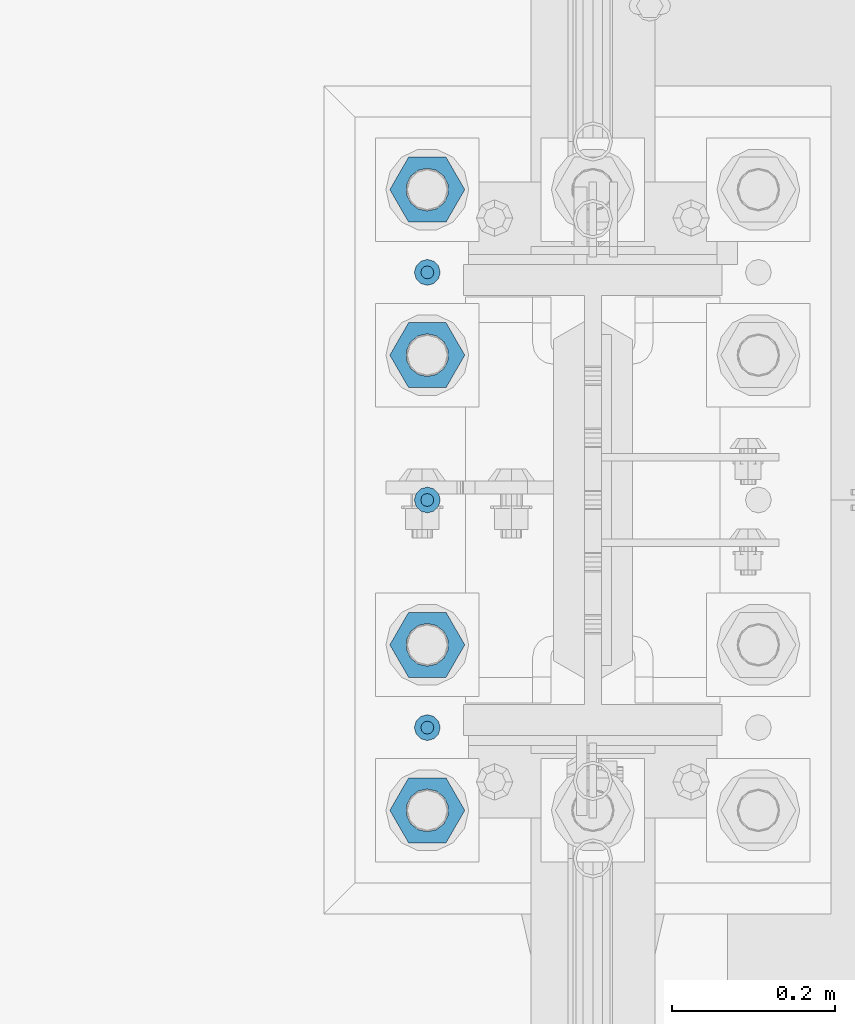
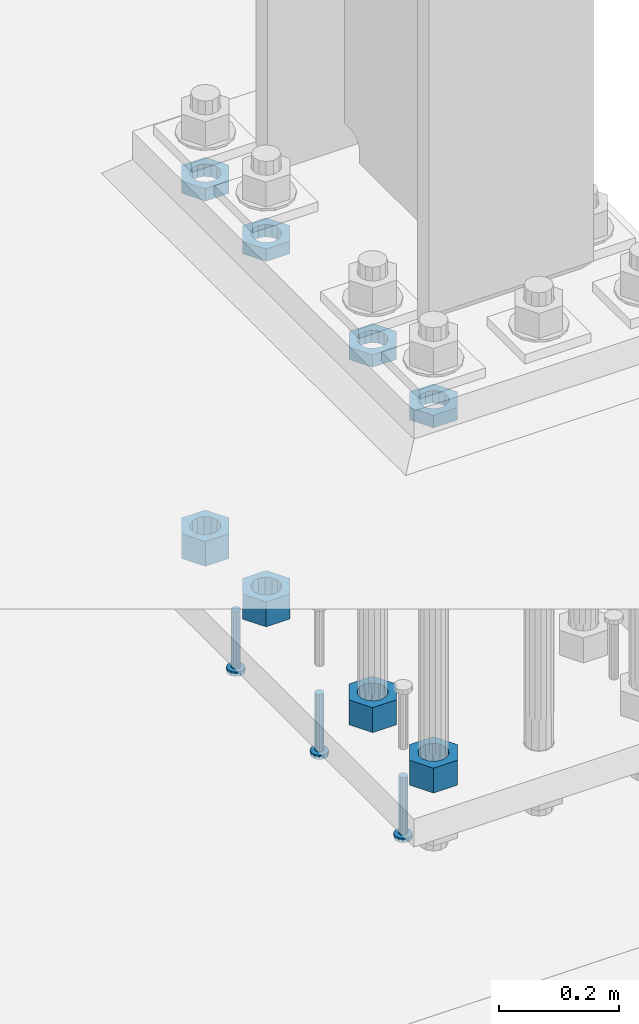
# One storey, part 1301 of 1876: 11 beams, 1 element without a shape of its own.
"""IFC2X3 building model written with IfcOpenShell, lengths in millimetres."""

from ifc_helpers import new_model, si_unit, frame, origin_with_axes, place, context, subcontext, project, spatial, faceted_brep, material, type_object, element, aggregate, save


model = new_model("IFC2X3")

# Units and contexts
model_context = context("Model", 3, precision=1e-05, world=origin_with_axes())
body_context = subcontext(model_context, "Body", "Model", "MODEL_VIEW")
ifc_project = project(units=[si_unit("LENGTHUNIT", "METRE", prefix="MILLI"), si_unit("AREAUNIT", "SQUARE_METRE"), si_unit("VOLUMEUNIT", "CUBIC_METRE"), si_unit("MASSUNIT", "GRAM", prefix="KILO"), si_unit("TIMEUNIT", "SECOND"), si_unit("PLANEANGLEUNIT", "RADIAN"), si_unit("SOLIDANGLEUNIT", "STERADIAN"), si_unit("THERMODYNAMICTEMPERATUREUNIT", "DEGREE_CELSIUS"), si_unit("LUMINOUSINTENSITYUNIT", "LUMEN")], contexts=[model_context])

# Site, building, storey
site_placement = place(None, origin_with_axes())
site = spatial("IfcSite", under=ifc_project, at=site_placement, CompositionType="ELEMENT")
building_placement = place(site_placement, origin_with_axes())
building = spatial("IfcBuilding", under=site, at=building_placement, Name="Undefined", CompositionType="ELEMENT")
storey_placement = place(building_placement, origin_with_axes())
storey = spatial("IfcBuildingStorey", under=building, at=storey_placement, Name="Undefined", CompositionType="ELEMENT", Elevation=0.0)

# Assembly, beams
assembly_placement = place(storey_placement, origin_with_axes())
assembly = element("IfcElementAssembly", 1, at=assembly_placement, inside=storey, Name="TEMPLATE", AssemblyPlace="NOTDEFINED", PredefinedType="RIGID_FRAME")
ifc_material_1 = material(Name="STEEL/A563")
beam_type_1 = type_object("IfcBeamType", Name="2_DIA. HALF_NUT", PredefinedType="NOTDEFINED")
beam_1_placement = place(assembly_placement, frame((7416.8, 8000.99999847412, 33.3375), z_axis=(0.0, -1.0, 0.0), x_axis=(0.0, 0.0, -1.0)))
beam_1 = element("IfcBeam", 2, at=beam_1_placement, type_object=beam_type_1, material=ifc_material_1, Name="NUT", ObjectType="2_DIA. HALF_NUT", context=body_context, shape_type="Brep", body=[
    faceted_brep([(0.0, -46.0369987487793, 9.09494701772928e-13), (0.0, -23.0184993743896, -39.869213104248), (25.4, -23.0184993743896, -39.869213104248), (25.4, -46.0369987487793, 9.09494701772928e-13), (0.0, 23.0184993743896, -39.869213104248), (25.4, 23.0184993743896, -39.869213104248), (0.0, 46.0369987487793, -9.09494701772928e-13), (25.4, 46.0369987487793, -9.09494701772928e-13), (0.0, 23.0184993743896, 39.869213104248), (25.4, 23.0184993743896, 39.869213104248), (0.0, -23.0184993743896, 39.869213104248), (25.4, -23.0184993743896, 39.869213104248), (0.0, 0.0, 26.1940002441406), (0.0, 11.3650617044514, 23.5999013092769), (25.4, 11.3650617044514, 23.5999013092769), (25.4, 0.0, 26.1940002441406), (0.0, 20.4791109456437, 16.3316083006703), (25.4, 20.4791109456437, 16.3316083006703), (0.0, 25.5370200498346, 5.82867859874477), (25.4, 25.5370200498346, 5.82867859874477), (0.0, 25.5370200498346, -5.82867859874477), (25.4, 25.5370200498346, -5.82867859874477), (0.0, 20.4791109456437, -16.3316083006703), (25.4, 20.4791109456437, -16.3316083006703), (0.0, 11.3650617044514, -23.5999013092769), (25.4, 11.3650617044514, -23.5999013092769), (0.0, 0.0, -26.1940002441406), (25.4, 0.0, -26.1940002441406), (0.0, -11.3650617044514, -23.5999013092769), (25.4, -11.3650617044514, -23.5999013092769), (0.0, -20.4791109456437, -16.3316083006703), (25.4, -20.4791109456437, -16.3316083006703), (0.0, -25.5370200498346, -5.82867859874477), (25.4, -25.5370200498346, -5.82867859874477), (0.0, -25.5370200498346, 5.82867859874477), (25.4, -25.5370200498346, 5.82867859874477), (0.0, -20.4791109456437, 16.3316083006703), (25.4, -20.4791109456437, 16.3316083006703), (0.0, -11.3650617044514, 23.5999013092769), (25.4, -11.3650617044514, 23.5999013092769)], [[[0, 1, 2, 3]], [[1, 4, 5, 2]], [[4, 6, 7, 5]], [[6, 8, 9, 7]], [[8, 10, 11, 9]], [[10, 0, 3, 11]], [[12, 13, 14, 15]], [[13, 16, 17, 14]], [[16, 18, 19, 17]], [[18, 20, 21, 19]], [[20, 22, 23, 21]], [[22, 24, 25, 23]], [[24, 26, 27, 25]], [[26, 28, 29, 27]], [[28, 30, 31, 29]], [[30, 32, 33, 31]], [[32, 34, 35, 33]], [[34, 36, 37, 35]], [[36, 38, 39, 37]], [[38, 12, 15, 39]], [[5, 7, 9, 11, 3, 2], [17, 19, 21, 23, 25, 27, 29, 31, 33, 35, 37, 39, 15, 14]], [[10, 8, 6, 4, 1, 0], [38, 36, 34, 32, 30, 28, 26, 24, 22, 20, 18, 16, 13, 12]]]),
])
beam_2_placement = place(assembly_placement, frame((7416.8, 7797.79999847412, 33.3375), z_axis=(0.0, -1.0, 0.0), x_axis=(0.0, 0.0, -1.0)))
beam_2 = element("IfcBeam", 3, at=beam_2_placement, type_object=beam_type_1, material=ifc_material_1, Name="NUT", ObjectType="2_DIA. HALF_NUT", context=body_context, shape_type="Brep", body=[
    faceted_brep([(0.0, -46.0369987487793, 9.09494701772928e-13), (0.0, -23.0184993743896, -39.869213104248), (25.4, -23.0184993743896, -39.869213104248), (25.4, -46.0369987487793, 9.09494701772928e-13), (0.0, 23.0184993743896, -39.869213104248), (25.4, 23.0184993743896, -39.869213104248), (0.0, 46.0369987487793, -9.09494701772928e-13), (25.4, 46.0369987487793, -9.09494701772928e-13), (0.0, 23.0184993743896, 39.869213104248), (25.4, 23.0184993743896, 39.869213104248), (0.0, -23.0184993743896, 39.869213104248), (25.4, -23.0184993743896, 39.869213104248), (0.0, 0.0, 26.1940002441406), (0.0, 11.3650617044514, 23.5999013092769), (25.4, 11.3650617044514, 23.5999013092769), (25.4, 0.0, 26.1940002441406), (0.0, 20.4791109456437, 16.3316083006703), (25.4, 20.4791109456437, 16.3316083006703), (0.0, 25.5370200498346, 5.82867859874477), (25.4, 25.5370200498346, 5.82867859874477), (0.0, 25.5370200498346, -5.82867859874477), (25.4, 25.5370200498346, -5.82867859874477), (0.0, 20.4791109456437, -16.3316083006703), (25.4, 20.4791109456437, -16.3316083006703), (0.0, 11.3650617044514, -23.5999013092769), (25.4, 11.3650617044514, -23.5999013092769), (0.0, 0.0, -26.1940002441406), (25.4, 0.0, -26.1940002441406), (0.0, -11.3650617044514, -23.5999013092769), (25.4, -11.3650617044514, -23.5999013092769), (0.0, -20.4791109456437, -16.3316083006703), (25.4, -20.4791109456437, -16.3316083006703), (0.0, -25.5370200498346, -5.82867859874477), (25.4, -25.5370200498346, -5.82867859874477), (0.0, -25.5370200498346, 5.82867859874477), (25.4, -25.5370200498346, 5.82867859874477), (0.0, -20.4791109456437, 16.3316083006703), (25.4, -20.4791109456437, 16.3316083006703), (0.0, -11.3650617044514, 23.5999013092769), (25.4, -11.3650617044514, 23.5999013092769)], [[[0, 1, 2, 3]], [[1, 4, 5, 2]], [[4, 6, 7, 5]], [[6, 8, 9, 7]], [[8, 10, 11, 9]], [[10, 0, 3, 11]], [[12, 13, 14, 15]], [[13, 16, 17, 14]], [[16, 18, 19, 17]], [[18, 20, 21, 19]], [[20, 22, 23, 21]], [[22, 24, 25, 23]], [[24, 26, 27, 25]], [[26, 28, 29, 27]], [[28, 30, 31, 29]], [[30, 32, 33, 31]], [[32, 34, 35, 33]], [[34, 36, 37, 35]], [[36, 38, 39, 37]], [[38, 12, 15, 39]], [[5, 7, 9, 11, 3, 2], [17, 19, 21, 23, 25, 27, 29, 31, 33, 35, 37, 39, 15, 14]], [[10, 8, 6, 4, 1, 0], [38, 36, 34, 32, 30, 28, 26, 24, 22, 20, 18, 16, 13, 12]]]),
])
beam_3_placement = place(assembly_placement, frame((7416.8, 7442.19999847412, 33.3375), z_axis=(0.0, -1.0, 0.0), x_axis=(0.0, 0.0, -1.0)))
beam_3 = element("IfcBeam", 4, at=beam_3_placement, type_object=beam_type_1, material=ifc_material_1, Name="NUT", ObjectType="2_DIA. HALF_NUT", context=body_context, shape_type="Brep", body=[
    faceted_brep([(0.0, -46.0369987487793, 9.09494701772928e-13), (0.0, -23.0184993743896, -39.869213104248), (25.4, -23.0184993743896, -39.869213104248), (25.4, -46.0369987487793, 9.09494701772928e-13), (0.0, 23.0184993743896, -39.869213104248), (25.4, 23.0184993743896, -39.869213104248), (0.0, 46.0369987487793, -9.09494701772928e-13), (25.4, 46.0369987487793, -9.09494701772928e-13), (0.0, 23.0184993743896, 39.869213104248), (25.4, 23.0184993743896, 39.869213104248), (0.0, -23.0184993743896, 39.869213104248), (25.4, -23.0184993743896, 39.869213104248), (0.0, 0.0, 26.1940002441406), (0.0, 11.3650617044514, 23.5999013092769), (25.4, 11.3650617044514, 23.5999013092769), (25.4, 0.0, 26.1940002441406), (0.0, 20.4791109456437, 16.3316083006703), (25.4, 20.4791109456437, 16.3316083006703), (0.0, 25.5370200498346, 5.82867859874477), (25.4, 25.5370200498346, 5.82867859874477), (0.0, 25.5370200498346, -5.82867859874477), (25.4, 25.5370200498346, -5.82867859874477), (0.0, 20.4791109456437, -16.3316083006703), (25.4, 20.4791109456437, -16.3316083006703), (0.0, 11.3650617044514, -23.5999013092769), (25.4, 11.3650617044514, -23.5999013092769), (0.0, 0.0, -26.1940002441406), (25.4, 0.0, -26.1940002441406), (0.0, -11.3650617044514, -23.5999013092769), (25.4, -11.3650617044514, -23.5999013092769), (0.0, -20.4791109456437, -16.3316083006703), (25.4, -20.4791109456437, -16.3316083006703), (0.0, -25.5370200498346, -5.82867859874477), (25.4, -25.5370200498346, -5.82867859874477), (0.0, -25.5370200498346, 5.82867859874477), (25.4, -25.5370200498346, 5.82867859874477), (0.0, -20.4791109456437, 16.3316083006703), (25.4, -20.4791109456437, 16.3316083006703), (0.0, -11.3650617044514, 23.5999013092769), (25.4, -11.3650617044514, 23.5999013092769)], [[[0, 1, 2, 3]], [[1, 4, 5, 2]], [[4, 6, 7, 5]], [[6, 8, 9, 7]], [[8, 10, 11, 9]], [[10, 0, 3, 11]], [[12, 13, 14, 15]], [[13, 16, 17, 14]], [[16, 18, 19, 17]], [[18, 20, 21, 19]], [[20, 22, 23, 21]], [[22, 24, 25, 23]], [[24, 26, 27, 25]], [[26, 28, 29, 27]], [[28, 30, 31, 29]], [[30, 32, 33, 31]], [[32, 34, 35, 33]], [[34, 36, 37, 35]], [[36, 38, 39, 37]], [[38, 12, 15, 39]], [[5, 7, 9, 11, 3, 2], [17, 19, 21, 23, 25, 27, 29, 31, 33, 35, 37, 39, 15, 14]], [[10, 8, 6, 4, 1, 0], [38, 36, 34, 32, 30, 28, 26, 24, 22, 20, 18, 16, 13, 12]]]),
])
beam_4_placement = place(assembly_placement, frame((7416.8, 7238.99999847412, 33.3375), z_axis=(0.0, -1.0, 0.0), x_axis=(0.0, 0.0, -1.0)))
beam_4 = element("IfcBeam", 5, at=beam_4_placement, type_object=beam_type_1, material=ifc_material_1, Name="NUT", ObjectType="2_DIA. HALF_NUT", context=body_context, shape_type="Brep", body=[
    faceted_brep([(0.0, -46.0369987487793, 9.09494701772928e-13), (0.0, -23.0184993743896, -39.869213104248), (25.4, -23.0184993743896, -39.869213104248), (25.4, -46.0369987487793, 9.09494701772928e-13), (0.0, 23.0184993743896, -39.869213104248), (25.4, 23.0184993743896, -39.869213104248), (0.0, 46.0369987487793, -9.09494701772928e-13), (25.4, 46.0369987487793, -9.09494701772928e-13), (0.0, 23.0184993743896, 39.869213104248), (25.4, 23.0184993743896, 39.869213104248), (0.0, -23.0184993743896, 39.869213104248), (25.4, -23.0184993743896, 39.869213104248), (0.0, 0.0, 26.1940002441406), (0.0, 11.3650617044514, 23.5999013092769), (25.4, 11.3650617044514, 23.5999013092769), (25.4, 0.0, 26.1940002441406), (0.0, 20.4791109456437, 16.3316083006703), (25.4, 20.4791109456437, 16.3316083006703), (0.0, 25.5370200498346, 5.82867859874477), (25.4, 25.5370200498346, 5.82867859874477), (0.0, 25.5370200498346, -5.82867859874477), (25.4, 25.5370200498346, -5.82867859874477), (0.0, 20.4791109456437, -16.3316083006703), (25.4, 20.4791109456437, -16.3316083006703), (0.0, 11.3650617044514, -23.5999013092769), (25.4, 11.3650617044514, -23.5999013092769), (0.0, 0.0, -26.1940002441406), (25.4, 0.0, -26.1940002441406), (0.0, -11.3650617044514, -23.5999013092769), (25.4, -11.3650617044514, -23.5999013092769), (0.0, -20.4791109456437, -16.3316083006703), (25.4, -20.4791109456437, -16.3316083006703), (0.0, -25.5370200498346, -5.82867859874477), (25.4, -25.5370200498346, -5.82867859874477), (0.0, -25.5370200498346, 5.82867859874477), (25.4, -25.5370200498346, 5.82867859874477), (0.0, -20.4791109456437, 16.3316083006703), (25.4, -20.4791109456437, 16.3316083006703), (0.0, -11.3650617044514, 23.5999013092769), (25.4, -11.3650617044514, 23.5999013092769)], [[[0, 1, 2, 3]], [[1, 4, 5, 2]], [[4, 6, 7, 5]], [[6, 8, 9, 7]], [[8, 10, 11, 9]], [[10, 0, 3, 11]], [[12, 13, 14, 15]], [[13, 16, 17, 14]], [[16, 18, 19, 17]], [[18, 20, 21, 19]], [[20, 22, 23, 21]], [[22, 24, 25, 23]], [[24, 26, 27, 25]], [[26, 28, 29, 27]], [[28, 30, 31, 29]], [[30, 32, 33, 31]], [[32, 34, 35, 33]], [[34, 36, 37, 35]], [[36, 38, 39, 37]], [[38, 12, 15, 39]], [[5, 7, 9, 11, 3, 2], [17, 19, 21, 23, 25, 27, 29, 31, 33, 35, 37, 39, 15, 14]], [[10, 8, 6, 4, 1, 0], [38, 36, 34, 32, 30, 28, 26, 24, 22, 20, 18, 16, 13, 12]]]),
])
beam_type_2 = type_object("IfcBeamType", Name="2_HEAVY_HEX_NUT", PredefinedType="NOTDEFINED")
beam_5_placement = place(assembly_placement, frame((7416.8, 7238.99999847412, -685.799998474121), z_axis=(0.0, -1.0, 0.0), x_axis=(0.0, 0.0, -1.0)))
beam_5 = element("IfcBeam", 6, at=beam_5_placement, type_object=beam_type_2, material=ifc_material_1, Name="NUT", ObjectType="2_HEAVY_HEX_NUT", context=body_context, shape_type="Brep", body=[
    faceted_brep([(0.0, -46.0369987487793, 9.09494701772928e-13), (0.0, -23.0184993743896, -39.869213104248), (50.8, -23.0184993743896, -39.869213104248), (50.8, -46.0369987487793, 9.09494701772928e-13), (0.0, 23.0184993743896, -39.869213104248), (50.8, 23.0184993743896, -39.869213104248), (0.0, 46.0369987487793, -9.09494701772928e-13), (50.8, 46.0369987487793, -9.09494701772928e-13), (0.0, 23.0184993743896, 39.869213104248), (50.8, 23.0184993743896, 39.869213104248), (0.0, -23.0184993743896, 39.869213104248), (50.8, -23.0184993743896, 39.869213104248), (0.0, 0.0, 26.1940002441406), (0.0, 11.3650617044514, 23.5999013092769), (50.8, 11.3650617044513, 23.5999013092771), (50.8, 0.0, 26.1940002441406), (0.0, 20.4791109456437, 16.3316083006703), (50.8, 20.4791109456439, 16.3316083006703), (0.0, 25.5370200498346, 5.82867859874477), (50.8, 25.5370200498343, 5.82867859874455), (0.0, 25.5370200498346, -5.82867859874477), (50.8, 25.5370200498343, -5.82867859874455), (0.0, 20.4791109456437, -16.3316083006703), (50.8, 20.4791109456439, -16.3316083006703), (0.0, 11.3650617044514, -23.5999013092769), (50.8, 11.3650617044514, -23.5999013092771), (0.0, 0.0, -26.1940002441406), (50.8, 0.0, -26.1940002441406), (0.0, -11.3650617044514, -23.5999013092769), (50.8, -11.3650617044513, -23.5999013092771), (0.0, -20.4791109456437, -16.3316083006703), (50.8, -20.4791109456439, -16.3316083006703), (0.0, -25.5370200498346, -5.82867859874477), (50.8, -25.5370200498343, -5.82867859874455), (0.0, -25.5370200498346, 5.82867859874477), (50.8, -25.5370200498343, 5.82867859874455), (0.0, -20.4791109456437, 16.3316083006703), (50.8, -20.4791109456439, 16.3316083006703), (0.0, -11.3650617044514, 23.5999013092769), (50.8, -11.3650617044514, 23.5999013092771)], [[[0, 1, 2, 3]], [[1, 4, 5, 2]], [[4, 6, 7, 5]], [[6, 8, 9, 7]], [[8, 10, 11, 9]], [[10, 0, 3, 11]], [[12, 13, 14, 15]], [[13, 16, 17, 14]], [[16, 18, 19, 17]], [[18, 20, 21, 19]], [[20, 22, 23, 21]], [[22, 24, 25, 23]], [[24, 26, 27, 25]], [[26, 28, 29, 27]], [[28, 30, 31, 29]], [[30, 32, 33, 31]], [[32, 34, 35, 33]], [[34, 36, 37, 35]], [[36, 38, 39, 37]], [[38, 12, 15, 39]], [[5, 7, 9, 11, 3, 2], [17, 19, 21, 23, 25, 27, 29, 31, 33, 35, 37, 39, 15, 14]], [[10, 8, 6, 4, 1, 0], [38, 36, 34, 32, 30, 28, 26, 24, 22, 20, 18, 16, 13, 12]]]),
])
beam_6_placement = place(assembly_placement, frame((7416.8, 7442.19999847412, -685.799998474121), z_axis=(0.0, -1.0, 0.0), x_axis=(0.0, 0.0, -1.0)))
beam_6 = element("IfcBeam", 7, at=beam_6_placement, type_object=beam_type_2, material=ifc_material_1, Name="NUT", ObjectType="2_HEAVY_HEX_NUT", context=body_context, shape_type="Brep", body=[
    faceted_brep([(0.0, -46.0369987487793, 9.09494701772928e-13), (0.0, -23.0184993743896, -39.869213104248), (50.8, -23.0184993743896, -39.869213104248), (50.8, -46.0369987487793, 9.09494701772928e-13), (0.0, 23.0184993743896, -39.869213104248), (50.8, 23.0184993743896, -39.869213104248), (0.0, 46.0369987487793, -9.09494701772928e-13), (50.8, 46.0369987487793, -9.09494701772928e-13), (0.0, 23.0184993743896, 39.869213104248), (50.8, 23.0184993743896, 39.869213104248), (0.0, -23.0184993743896, 39.869213104248), (50.8, -23.0184993743896, 39.869213104248), (0.0, 0.0, 26.1940002441406), (0.0, 11.3650617044514, 23.5999013092769), (50.8, 11.3650617044513, 23.5999013092771), (50.8, 0.0, 26.1940002441406), (0.0, 20.4791109456437, 16.3316083006703), (50.8, 20.4791109456439, 16.3316083006703), (0.0, 25.5370200498346, 5.82867859874477), (50.8, 25.5370200498343, 5.82867859874455), (0.0, 25.5370200498346, -5.82867859874477), (50.8, 25.5370200498343, -5.82867859874455), (0.0, 20.4791109456437, -16.3316083006703), (50.8, 20.4791109456439, -16.3316083006703), (0.0, 11.3650617044514, -23.5999013092769), (50.8, 11.3650617044514, -23.5999013092771), (0.0, 0.0, -26.1940002441406), (50.8, 0.0, -26.1940002441406), (0.0, -11.3650617044514, -23.5999013092769), (50.8, -11.3650617044513, -23.5999013092771), (0.0, -20.4791109456437, -16.3316083006703), (50.8, -20.4791109456439, -16.3316083006703), (0.0, -25.5370200498346, -5.82867859874477), (50.8, -25.5370200498343, -5.82867859874455), (0.0, -25.5370200498346, 5.82867859874477), (50.8, -25.5370200498343, 5.82867859874455), (0.0, -20.4791109456437, 16.3316083006703), (50.8, -20.4791109456439, 16.3316083006703), (0.0, -11.3650617044514, 23.5999013092769), (50.8, -11.3650617044514, 23.5999013092771)], [[[0, 1, 2, 3]], [[1, 4, 5, 2]], [[4, 6, 7, 5]], [[6, 8, 9, 7]], [[8, 10, 11, 9]], [[10, 0, 3, 11]], [[12, 13, 14, 15]], [[13, 16, 17, 14]], [[16, 18, 19, 17]], [[18, 20, 21, 19]], [[20, 22, 23, 21]], [[22, 24, 25, 23]], [[24, 26, 27, 25]], [[26, 28, 29, 27]], [[28, 30, 31, 29]], [[30, 32, 33, 31]], [[32, 34, 35, 33]], [[34, 36, 37, 35]], [[36, 38, 39, 37]], [[38, 12, 15, 39]], [[5, 7, 9, 11, 3, 2], [17, 19, 21, 23, 25, 27, 29, 31, 33, 35, 37, 39, 15, 14]], [[10, 8, 6, 4, 1, 0], [38, 36, 34, 32, 30, 28, 26, 24, 22, 20, 18, 16, 13, 12]]]),
])
beam_7_placement = place(assembly_placement, frame((7416.8, 7797.79999847412, -685.799998474121), z_axis=(0.0, -1.0, 0.0), x_axis=(0.0, 0.0, -1.0)))
beam_7 = element("IfcBeam", 8, at=beam_7_placement, type_object=beam_type_2, material=ifc_material_1, Name="NUT", ObjectType="2_HEAVY_HEX_NUT", context=body_context, shape_type="Brep", body=[
    faceted_brep([(0.0, -46.0369987487793, 9.09494701772928e-13), (0.0, -23.0184993743896, -39.869213104248), (50.8, -23.0184993743896, -39.869213104248), (50.8, -46.0369987487793, 9.09494701772928e-13), (0.0, 23.0184993743896, -39.869213104248), (50.8, 23.0184993743896, -39.869213104248), (0.0, 46.0369987487793, -9.09494701772928e-13), (50.8, 46.0369987487793, -9.09494701772928e-13), (0.0, 23.0184993743896, 39.869213104248), (50.8, 23.0184993743896, 39.869213104248), (0.0, -23.0184993743896, 39.869213104248), (50.8, -23.0184993743896, 39.869213104248), (0.0, 0.0, 26.1940002441406), (0.0, 11.3650617044514, 23.5999013092769), (50.8, 11.3650617044513, 23.5999013092771), (50.8, 0.0, 26.1940002441406), (0.0, 20.4791109456437, 16.3316083006703), (50.8, 20.4791109456439, 16.3316083006703), (0.0, 25.5370200498346, 5.82867859874477), (50.8, 25.5370200498343, 5.82867859874455), (0.0, 25.5370200498346, -5.82867859874477), (50.8, 25.5370200498343, -5.82867859874455), (0.0, 20.4791109456437, -16.3316083006703), (50.8, 20.4791109456439, -16.3316083006703), (0.0, 11.3650617044514, -23.5999013092769), (50.8, 11.3650617044514, -23.5999013092771), (0.0, 0.0, -26.1940002441406), (50.8, 0.0, -26.1940002441406), (0.0, -11.3650617044514, -23.5999013092769), (50.8, -11.3650617044513, -23.5999013092771), (0.0, -20.4791109456437, -16.3316083006703), (50.8, -20.4791109456439, -16.3316083006703), (0.0, -25.5370200498346, -5.82867859874477), (50.8, -25.5370200498343, -5.82867859874455), (0.0, -25.5370200498346, 5.82867859874477), (50.8, -25.5370200498343, 5.82867859874455), (0.0, -20.4791109456437, 16.3316083006703), (50.8, -20.4791109456439, 16.3316083006703), (0.0, -11.3650617044514, 23.5999013092769), (50.8, -11.3650617044514, 23.5999013092771)], [[[0, 1, 2, 3]], [[1, 4, 5, 2]], [[4, 6, 7, 5]], [[6, 8, 9, 7]], [[8, 10, 11, 9]], [[10, 0, 3, 11]], [[12, 13, 14, 15]], [[13, 16, 17, 14]], [[16, 18, 19, 17]], [[18, 20, 21, 19]], [[20, 22, 23, 21]], [[22, 24, 25, 23]], [[24, 26, 27, 25]], [[26, 28, 29, 27]], [[28, 30, 31, 29]], [[30, 32, 33, 31]], [[32, 34, 35, 33]], [[34, 36, 37, 35]], [[36, 38, 39, 37]], [[38, 12, 15, 39]], [[5, 7, 9, 11, 3, 2], [17, 19, 21, 23, 25, 27, 29, 31, 33, 35, 37, 39, 15, 14]], [[10, 8, 6, 4, 1, 0], [38, 36, 34, 32, 30, 28, 26, 24, 22, 20, 18, 16, 13, 12]]]),
])
beam_8_placement = place(assembly_placement, frame((7416.8, 8000.99999847412, -685.799998474121), z_axis=(0.0, -1.0, 0.0), x_axis=(0.0, 0.0, -1.0)))
beam_8 = element("IfcBeam", 9, at=beam_8_placement, type_object=beam_type_2, material=ifc_material_1, Name="NUT", ObjectType="2_HEAVY_HEX_NUT", context=body_context, shape_type="Brep", body=[
    faceted_brep([(0.0, -46.0369987487793, 9.09494701772928e-13), (0.0, -23.0184993743896, -39.869213104248), (50.8, -23.0184993743896, -39.869213104248), (50.8, -46.0369987487793, 9.09494701772928e-13), (0.0, 23.0184993743896, -39.869213104248), (50.8, 23.0184993743896, -39.869213104248), (0.0, 46.0369987487793, -9.09494701772928e-13), (50.8, 46.0369987487793, -9.09494701772928e-13), (0.0, 23.0184993743896, 39.869213104248), (50.8, 23.0184993743896, 39.869213104248), (0.0, -23.0184993743896, 39.869213104248), (50.8, -23.0184993743896, 39.869213104248), (0.0, 0.0, 26.1940002441406), (0.0, 11.3650617044514, 23.5999013092769), (50.8, 11.3650617044513, 23.5999013092771), (50.8, 0.0, 26.1940002441406), (0.0, 20.4791109456437, 16.3316083006703), (50.8, 20.4791109456439, 16.3316083006703), (0.0, 25.5370200498346, 5.82867859874477), (50.8, 25.5370200498343, 5.82867859874455), (0.0, 25.5370200498346, -5.82867859874477), (50.8, 25.5370200498343, -5.82867859874455), (0.0, 20.4791109456437, -16.3316083006703), (50.8, 20.4791109456439, -16.3316083006703), (0.0, 11.3650617044514, -23.5999013092769), (50.8, 11.3650617044514, -23.5999013092771), (0.0, 0.0, -26.1940002441406), (50.8, 0.0, -26.1940002441406), (0.0, -11.3650617044514, -23.5999013092769), (50.8, -11.3650617044513, -23.5999013092771), (0.0, -20.4791109456437, -16.3316083006703), (50.8, -20.4791109456439, -16.3316083006703), (0.0, -25.5370200498346, -5.82867859874477), (50.8, -25.5370200498343, -5.82867859874455), (0.0, -25.5370200498346, 5.82867859874477), (50.8, -25.5370200498343, 5.82867859874455), (0.0, -20.4791109456437, 16.3316083006703), (50.8, -20.4791109456439, 16.3316083006703), (0.0, -11.3650617044514, 23.5999013092769), (50.8, -11.3650617044514, 23.5999013092771)], [[[0, 1, 2, 3]], [[1, 4, 5, 2]], [[4, 6, 7, 5]], [[6, 8, 9, 7]], [[8, 10, 11, 9]], [[10, 0, 3, 11]], [[12, 13, 14, 15]], [[13, 16, 17, 14]], [[16, 18, 19, 17]], [[18, 20, 21, 19]], [[20, 22, 23, 21]], [[22, 24, 25, 23]], [[24, 26, 27, 25]], [[26, 28, 29, 27]], [[28, 30, 31, 29]], [[30, 32, 33, 31]], [[32, 34, 35, 33]], [[34, 36, 37, 35]], [[36, 38, 39, 37]], [[38, 12, 15, 39]], [[5, 7, 9, 11, 3, 2], [17, 19, 21, 23, 25, 27, 29, 31, 33, 35, 37, 39, 15, 14]], [[10, 8, 6, 4, 1, 0], [38, 36, 34, 32, 30, 28, 26, 24, 22, 20, 18, 16, 13, 12]]]),
])
ifc_material_2 = material(Name="STEEL/A108")
beam_type_3 = type_object("IfcBeamType", Name="5/8-DIA_HEADED ANCHOR STUD", PredefinedType="NOTDEFINED")
beam_9_placement = place(assembly_placement, frame((7416.8, 7899.4, -793.75), z_axis=(1.0, 0.0, 0.0), x_axis=(0.0, 0.0, -1.0)))
beam_9 = element("IfcBeam", 10, at=beam_9_placement, type_object=beam_type_3, material=ifc_material_2, Name="HEADED ANCHOR STUD", ObjectType="5/8-DIA_HEADED ANCHOR STUD", context=body_context, shape_type="Brep", body=[
    faceted_brep([(0.0, -7.94000005722046, 0.0), (0.0, -6.86999988555908, -3.97000002861023), (116.84, -6.86999988555908, -3.97000002861023), (116.84, -7.94000005722046, 0.0), (0.0, -3.97000002861023, -6.86999988555908), (116.84, -3.97000002861023, -6.86999988555908), (0.0, 0.0, -7.94000005722046), (116.84, 0.0, -7.94000005722046), (0.0, 3.97000002861023, -6.86999988555908), (116.84, 3.97000002861023, -6.86999988555908), (0.0, 6.86999988555908, -3.97000002861023), (116.84, 6.86999988555908, -3.97000002861023), (0.0, 7.94000005722046, 0.0), (116.84, 7.94000005722046, 0.0), (0.0, 6.86999988555908, 3.97000002861023), (116.84, 6.86999988555908, 3.97000002861023), (0.0, 3.97000002861023, 6.86999988555908), (116.84, 3.97000002861023, 6.86999988555908), (0.0, 0.0, 7.94000005722046), (116.84, 0.0, 7.94000005722046), (0.0, -3.97000002861023, 6.86999988555908), (116.84, -3.97000002861023, 6.86999988555908), (0.0, -6.86999988555908, 3.97000002861023), (116.84, -6.86999988555908, 3.97000002861023), (118.11, -13.75, -7.94000005722046), (118.11, -15.8800001144409, 0.0), (118.11, -7.94000005722046, -13.75), (118.11, 0.0, -15.8800001144409), (118.11, 7.94000005722046, -13.75), (118.11, 13.75, -7.94000005722046), (118.11, 15.8800001144409, 0.0), (118.11, 13.75, 7.94000005722046), (118.11, 7.94000005722046, 13.75), (118.11, 0.0, 15.8800001144409), (118.11, -7.94000005722046, 13.75), (118.11, -13.75, 7.94000005722046), (127.0, -13.75, -7.94000005722046), (127.0, -15.8800001144409, 0.0), (127.0, -7.94000005722046, -13.75), (127.0, 0.0, -15.8800001144409), (127.0, 7.94000005722046, -13.75), (127.0, 13.75, -7.94000005722046), (127.0, 15.8800001144409, 0.0), (127.0, 13.75, 7.94000005722046), (127.0, 7.94000005722046, 13.75), (127.0, 0.0, 15.8800001144409), (127.0, -7.94000005722046, 13.75), (127.0, -13.75, 7.94000005722046)], [[[0, 1, 2, 3]], [[1, 4, 5, 2]], [[4, 6, 7, 5]], [[6, 8, 9, 7]], [[8, 10, 11, 9]], [[10, 12, 13, 11]], [[12, 14, 15, 13]], [[14, 16, 17, 15]], [[16, 18, 19, 17]], [[18, 20, 21, 19]], [[20, 22, 23, 21]], [[22, 0, 3, 23]], [[22, 20, 18, 16, 14, 12, 10, 8, 6, 4, 1, 0]], [[3, 2, 24, 25]], [[2, 5, 26, 24]], [[5, 7, 27, 26]], [[7, 9, 28, 27]], [[9, 11, 29, 28]], [[11, 13, 30, 29]], [[13, 15, 31, 30]], [[15, 17, 32, 31]], [[17, 19, 33, 32]], [[19, 21, 34, 33]], [[21, 23, 35, 34]], [[23, 3, 25, 35]], [[25, 24, 36, 37]], [[24, 26, 38, 36]], [[26, 27, 39, 38]], [[27, 28, 40, 39]], [[28, 29, 41, 40]], [[29, 30, 42, 41]], [[30, 31, 43, 42]], [[31, 32, 44, 43]], [[32, 33, 45, 44]], [[33, 34, 46, 45]], [[34, 35, 47, 46]], [[35, 25, 37, 47]], [[38, 39, 40, 41, 42, 43, 44, 45, 46, 47, 37, 36]]]),
])
beam_10_placement = place(assembly_placement, frame((7416.8, 7340.6, -793.75), z_axis=(1.0, 0.0, 0.0), x_axis=(0.0, 0.0, -1.0)))
beam_10 = element("IfcBeam", 11, at=beam_10_placement, type_object=beam_type_3, material=ifc_material_2, Name="HEADED ANCHOR STUD", ObjectType="5/8-DIA_HEADED ANCHOR STUD", context=body_context, shape_type="Brep", body=[
    faceted_brep([(0.0, -7.94000005722046, 0.0), (0.0, -6.86999988555908, -3.97000002861023), (116.84, -6.86999988555908, -3.97000002861023), (116.84, -7.94000005722046, 0.0), (0.0, -3.97000002861023, -6.86999988555908), (116.84, -3.97000002861023, -6.86999988555908), (0.0, 0.0, -7.94000005722046), (116.84, 0.0, -7.94000005722046), (0.0, 3.97000002861023, -6.86999988555908), (116.84, 3.97000002861023, -6.86999988555908), (0.0, 6.86999988555908, -3.97000002861023), (116.84, 6.86999988555908, -3.97000002861023), (0.0, 7.94000005722046, 0.0), (116.84, 7.94000005722046, 0.0), (0.0, 6.86999988555908, 3.97000002861023), (116.84, 6.86999988555908, 3.97000002861023), (0.0, 3.97000002861023, 6.86999988555908), (116.84, 3.97000002861023, 6.86999988555908), (0.0, 0.0, 7.94000005722046), (116.84, 0.0, 7.94000005722046), (0.0, -3.97000002861023, 6.86999988555908), (116.84, -3.97000002861023, 6.86999988555908), (0.0, -6.86999988555908, 3.97000002861023), (116.84, -6.86999988555908, 3.97000002861023), (118.11, -13.75, -7.94000005722046), (118.11, -15.8800001144409, 0.0), (118.11, -7.94000005722046, -13.75), (118.11, 0.0, -15.8800001144409), (118.11, 7.94000005722046, -13.75), (118.11, 13.75, -7.94000005722046), (118.11, 15.8800001144409, 0.0), (118.11, 13.75, 7.94000005722046), (118.11, 7.94000005722046, 13.75), (118.11, 0.0, 15.8800001144409), (118.11, -7.94000005722046, 13.75), (118.11, -13.75, 7.94000005722046), (127.0, -13.75, -7.94000005722046), (127.0, -15.8800001144409, 0.0), (127.0, -7.94000005722046, -13.75), (127.0, 0.0, -15.8800001144409), (127.0, 7.94000005722046, -13.75), (127.0, 13.75, -7.94000005722046), (127.0, 15.8800001144409, 0.0), (127.0, 13.75, 7.94000005722046), (127.0, 7.94000005722046, 13.75), (127.0, 0.0, 15.8800001144409), (127.0, -7.94000005722046, 13.75), (127.0, -13.75, 7.94000005722046)], [[[0, 1, 2, 3]], [[1, 4, 5, 2]], [[4, 6, 7, 5]], [[6, 8, 9, 7]], [[8, 10, 11, 9]], [[10, 12, 13, 11]], [[12, 14, 15, 13]], [[14, 16, 17, 15]], [[16, 18, 19, 17]], [[18, 20, 21, 19]], [[20, 22, 23, 21]], [[22, 0, 3, 23]], [[22, 20, 18, 16, 14, 12, 10, 8, 6, 4, 1, 0]], [[3, 2, 24, 25]], [[2, 5, 26, 24]], [[5, 7, 27, 26]], [[7, 9, 28, 27]], [[9, 11, 29, 28]], [[11, 13, 30, 29]], [[13, 15, 31, 30]], [[15, 17, 32, 31]], [[17, 19, 33, 32]], [[19, 21, 34, 33]], [[21, 23, 35, 34]], [[23, 3, 25, 35]], [[25, 24, 36, 37]], [[24, 26, 38, 36]], [[26, 27, 39, 38]], [[27, 28, 40, 39]], [[28, 29, 41, 40]], [[29, 30, 42, 41]], [[30, 31, 43, 42]], [[31, 32, 44, 43]], [[32, 33, 45, 44]], [[33, 34, 46, 45]], [[34, 35, 47, 46]], [[35, 25, 37, 47]], [[38, 39, 40, 41, 42, 43, 44, 45, 46, 47, 37, 36]]]),
])
beam_11_placement = place(assembly_placement, frame((7416.8, 7620.0, -793.75), z_axis=(1.0, 0.0, 0.0), x_axis=(0.0, 0.0, -1.0)))
beam_11 = element("IfcBeam", 12, at=beam_11_placement, type_object=beam_type_3, material=ifc_material_2, Name="HEADED ANCHOR STUD", ObjectType="5/8-DIA_HEADED ANCHOR STUD", context=body_context, shape_type="Brep", body=[
    faceted_brep([(0.0, -7.94000005722046, 0.0), (0.0, -6.86999988555908, -3.97000002861023), (116.84, -6.86999988555908, -3.97000002861023), (116.84, -7.94000005722046, 0.0), (0.0, -3.97000002861023, -6.86999988555908), (116.84, -3.97000002861023, -6.86999988555908), (0.0, 0.0, -7.94000005722046), (116.84, 0.0, -7.94000005722046), (0.0, 3.97000002861023, -6.86999988555908), (116.84, 3.97000002861023, -6.86999988555908), (0.0, 6.86999988555908, -3.97000002861023), (116.84, 6.86999988555908, -3.97000002861023), (0.0, 7.94000005722046, 0.0), (116.84, 7.94000005722046, 0.0), (0.0, 6.86999988555908, 3.97000002861023), (116.84, 6.86999988555908, 3.97000002861023), (0.0, 3.97000002861023, 6.86999988555908), (116.84, 3.97000002861023, 6.86999988555908), (0.0, 0.0, 7.94000005722046), (116.84, 0.0, 7.94000005722046), (0.0, -3.97000002861023, 6.86999988555908), (116.84, -3.97000002861023, 6.86999988555908), (0.0, -6.86999988555908, 3.97000002861023), (116.84, -6.86999988555908, 3.97000002861023), (118.11, -13.75, -7.94000005722046), (118.11, -15.8800001144409, 0.0), (118.11, -7.94000005722046, -13.75), (118.11, 0.0, -15.8800001144409), (118.11, 7.94000005722046, -13.75), (118.11, 13.75, -7.94000005722046), (118.11, 15.8800001144409, 0.0), (118.11, 13.75, 7.94000005722046), (118.11, 7.94000005722046, 13.75), (118.11, 0.0, 15.8800001144409), (118.11, -7.94000005722046, 13.75), (118.11, -13.75, 7.94000005722046), (127.0, -13.75, -7.94000005722046), (127.0, -15.8800001144409, 0.0), (127.0, -7.94000005722046, -13.75), (127.0, 0.0, -15.8800001144409), (127.0, 7.94000005722046, -13.75), (127.0, 13.75, -7.94000005722046), (127.0, 15.8800001144409, 0.0), (127.0, 13.75, 7.94000005722046), (127.0, 7.94000005722046, 13.75), (127.0, 0.0, 15.8800001144409), (127.0, -7.94000005722046, 13.75), (127.0, -13.75, 7.94000005722046)], [[[0, 1, 2, 3]], [[1, 4, 5, 2]], [[4, 6, 7, 5]], [[6, 8, 9, 7]], [[8, 10, 11, 9]], [[10, 12, 13, 11]], [[12, 14, 15, 13]], [[14, 16, 17, 15]], [[16, 18, 19, 17]], [[18, 20, 21, 19]], [[20, 22, 23, 21]], [[22, 0, 3, 23]], [[22, 20, 18, 16, 14, 12, 10, 8, 6, 4, 1, 0]], [[3, 2, 24, 25]], [[2, 5, 26, 24]], [[5, 7, 27, 26]], [[7, 9, 28, 27]], [[9, 11, 29, 28]], [[11, 13, 30, 29]], [[13, 15, 31, 30]], [[15, 17, 32, 31]], [[17, 19, 33, 32]], [[19, 21, 34, 33]], [[21, 23, 35, 34]], [[23, 3, 25, 35]], [[25, 24, 36, 37]], [[24, 26, 38, 36]], [[26, 27, 39, 38]], [[27, 28, 40, 39]], [[28, 29, 41, 40]], [[29, 30, 42, 41]], [[30, 31, 43, 42]], [[31, 32, 44, 43]], [[32, 33, 45, 44]], [[33, 34, 46, 45]], [[34, 35, 47, 46]], [[35, 25, 37, 47]], [[38, 39, 40, 41, 42, 43, 44, 45, 46, 47, 37, 36]]]),
])
aggregate(assembly, [beam_1, beam_2, beam_3, beam_4, beam_5, beam_6, beam_7, beam_8, beam_9, beam_10, beam_11])

save(model, "model.ifc")
